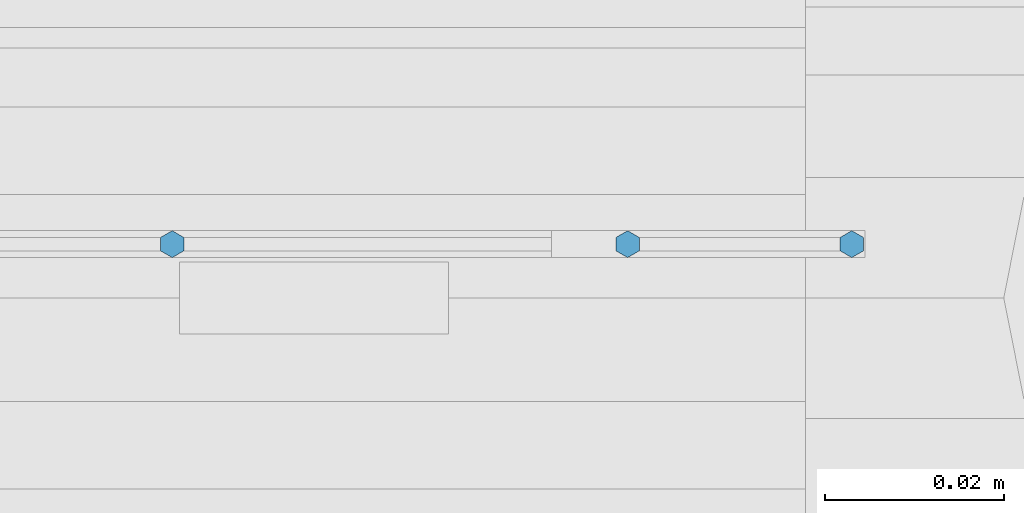
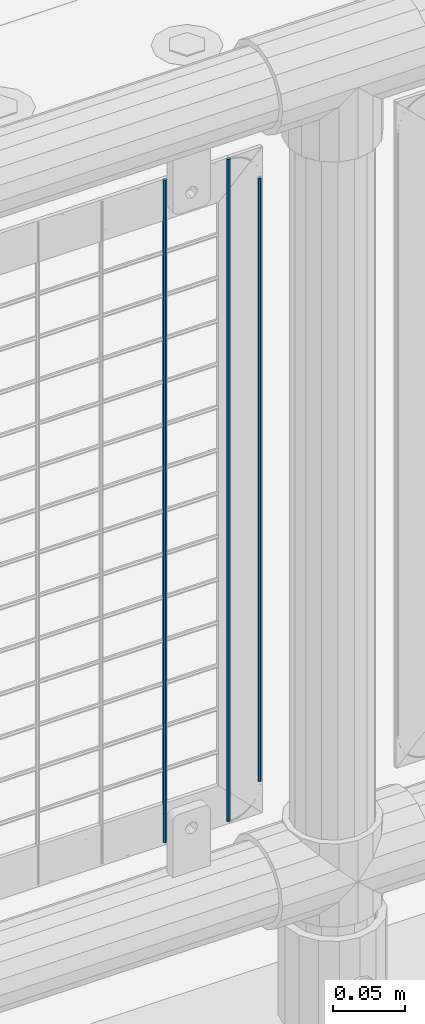
# One storey, part 83 of 270: 3 columns.
"""IFC2X3 building model written with IfcOpenShell, lengths in millimetres."""

from ifc_helpers import new_model, si_unit, frame, origin_with_axes, place, context, subcontext, project, spatial, faceted_brep, material, type_object, element, save


model = new_model("IFC2X3")

# Units and contexts
model_context = context("Model", 3, precision=1e-05, world=origin_with_axes())
body_context = subcontext(model_context, "Body", "Model", "MODEL_VIEW")
ifc_project = project(units=[si_unit("LENGTHUNIT", "METRE", prefix="MILLI"), si_unit("AREAUNIT", "SQUARE_METRE"), si_unit("VOLUMEUNIT", "CUBIC_METRE"), si_unit("MASSUNIT", "GRAM", prefix="KILO"), si_unit("TIMEUNIT", "SECOND"), si_unit("PLANEANGLEUNIT", "RADIAN"), si_unit("SOLIDANGLEUNIT", "STERADIAN"), si_unit("THERMODYNAMICTEMPERATUREUNIT", "DEGREE_CELSIUS"), si_unit("LUMINOUSINTENSITYUNIT", "LUMEN")], contexts=[model_context])

# Site, building, storey
site_placement = place(None, origin_with_axes())
site = spatial("IfcSite", under=ifc_project, at=site_placement, CompositionType="ELEMENT")
building_placement = place(site_placement, origin_with_axes())
building = spatial("IfcBuilding", under=site, at=building_placement, Name="Standard", CompositionType="ELEMENT")
storey_placement = place(building_placement, origin_with_axes())
storey = spatial("IfcBuildingStorey", under=building, at=storey_placement, Name="Undefined", CompositionType="ELEMENT", Elevation=0.0)

# Columns
ifc_material = material(Name="Misc_Undefined")
column_type = type_object("IfcColumnType", Name="D3", PredefinedType="NOTDEFINED")
for number, where, z_axis, x_axis in (
    (1, (7022.204, -16329.5, 353.02), (-1.0, 0.0, 0.0), (0.0, 0.0, 1.0)),
    (2, (7072.997, -16329.5, 353.02), (-1.0, 0.0, 0.0), (0.0, 0.0, 1.0)),
):
    element("IfcColumn", number, at=place(storey_placement, frame(where, z_axis=z_axis, x_axis=x_axis)), inside=storey, type_object=column_type, material=ifc_material, ObjectType="D3", context=body_context, shape_type="Brep", body=[
        faceted_brep([(0.0, -1.5, 0.0), (0.0, -0.75, -1.29903810567669), (560.0, -0.75, -1.29903810567703), (560.0, -1.5, 0.0), (0.0, 0.75, -1.29903810567669), (560.0, 0.75, -1.29903810567703), (0.0, 1.5, 0.0), (560.0, 1.5, 0.0), (0.0, 0.75, 1.29903810567669), (560.0, 0.75, 1.29903810567703), (0.0, -0.75, 1.29903810567669), (560.0, -0.75, 1.29903810567703)], [[[0, 1, 2, 3]], [[1, 4, 5, 2]], [[4, 6, 7, 5]], [[6, 8, 9, 7]], [[8, 10, 11, 9]], [[10, 0, 3, 11]], [[5, 7, 9, 11, 3, 2]], [[10, 8, 6, 4, 1, 0]]]),
    ])
column_placement = place(storey_placement, frame((7098.0, -16329.5, 378.02), z_axis=(-1.0, 0.0, 0.0), x_axis=(0.0, 0.0, 1.0)))
element("IfcColumn", 3, at=column_placement, inside=storey, type_object=column_type, material=ifc_material, ObjectType="D3", context=body_context, shape_type="Brep", body=[
    faceted_brep([(0.0, -1.5, 0.0), (0.0, -0.75, -1.29903810567669), (510.0, -0.75, -1.29903810567703), (510.0, -1.5, 0.0), (0.0, 0.75, -1.29903810567669), (510.0, 0.75, -1.29903810567703), (0.0, 1.5, 0.0), (510.0, 1.5, 0.0), (0.0, 0.75, 1.29903810567669), (510.0, 0.75, 1.29903810567703), (0.0, -0.75, 1.29903810567669), (510.0, -0.75, 1.29903810567703)], [[[0, 1, 2, 3]], [[1, 4, 5, 2]], [[4, 6, 7, 5]], [[6, 8, 9, 7]], [[8, 10, 11, 9]], [[10, 0, 3, 11]], [[5, 7, 9, 11, 3, 2]], [[10, 8, 6, 4, 1, 0]]]),
])

save(model, "model.ifc")
